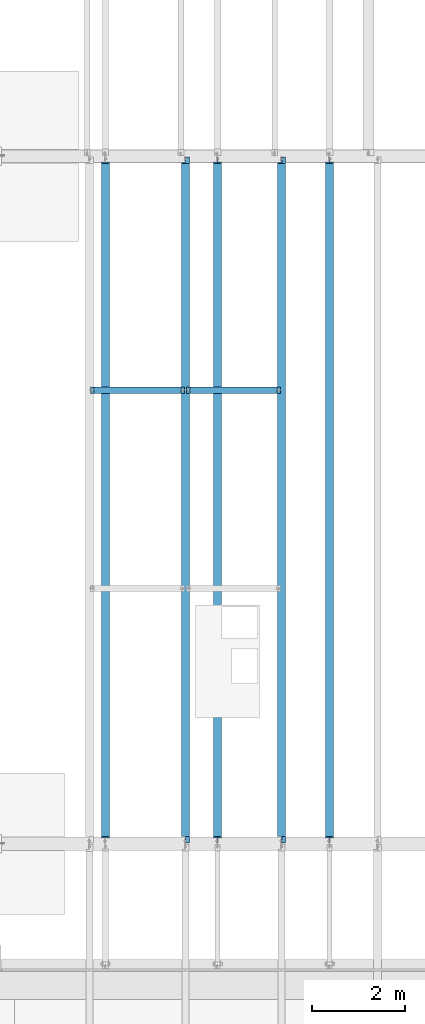
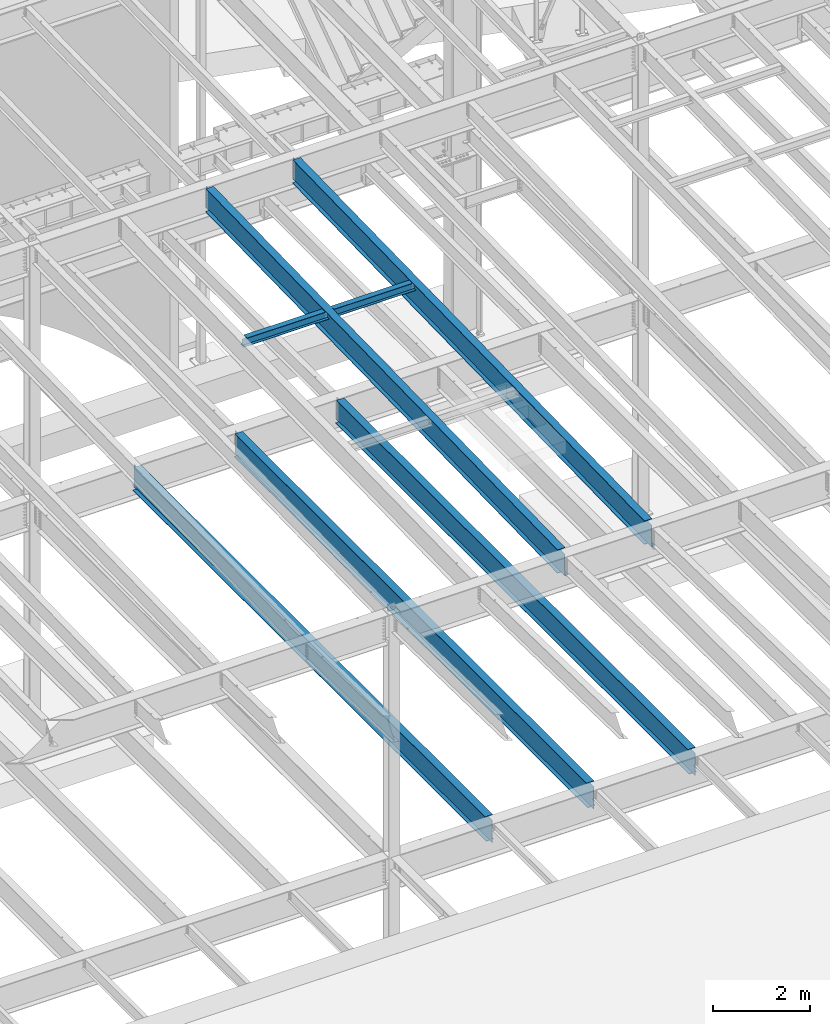
# One storey, part 1107 of 1763: 7 beams, 7 elements without a shape of their own.
"""IFC2X3 building model written with IfcOpenShell, lengths in millimetres."""

from ifc_helpers import new_model, si_unit, frame, origin_with_axes, place, context, subcontext, project, spatial, faceted_brep, material, type_object, element, aggregate, save


model = new_model("IFC2X3")

# Units and contexts
model_context = context("Model", 3, precision=1e-05, world=origin_with_axes())
body_context = subcontext(model_context, "Body", "Model", "MODEL_VIEW")
ifc_project = project(units=[si_unit("LENGTHUNIT", "METRE", prefix="MILLI"), si_unit("AREAUNIT", "SQUARE_METRE"), si_unit("VOLUMEUNIT", "CUBIC_METRE"), si_unit("MASSUNIT", "GRAM", prefix="KILO"), si_unit("TIMEUNIT", "SECOND"), si_unit("PLANEANGLEUNIT", "RADIAN"), si_unit("SOLIDANGLEUNIT", "STERADIAN"), si_unit("THERMODYNAMICTEMPERATUREUNIT", "DEGREE_CELSIUS"), si_unit("LUMINOUSINTENSITYUNIT", "LUMEN")], contexts=[model_context])

# Site, building, storey
site_placement = place(None, origin_with_axes())
site = spatial("IfcSite", under=ifc_project, at=site_placement, CompositionType="ELEMENT")
building_placement = place(site_placement, origin_with_axes())
building = spatial("IfcBuilding", under=site, at=building_placement, Name="Undefined", CompositionType="ELEMENT")
storey_placement = place(building_placement, origin_with_axes())
storey = spatial("IfcBuildingStorey", under=building, at=storey_placement, Name="Undefined", CompositionType="ELEMENT", Elevation=0.0)

# Assembly, beam
assembly_1_placement = place(storey_placement, origin_with_axes())
assembly_1 = element("IfcElementAssembly", 1, at=assembly_1_placement, inside=storey, Name="BEAM", AssemblyPlace="NOTDEFINED", PredefinedType="RIGID_FRAME")
ifc_material = material(Name="STEEL/A992")
beam_type_1 = type_object("IfcBeamType", Name="W8X18", PredefinedType="NOTDEFINED")
beam_1_placement = place(assembly_1_placement, frame((-45273.1229879841, 39776.399940754, 11388.9111170495), z_axis=(0.0, 0.0, 1.0), x_axis=(1.0, 0.0, 0.0)))
beam_1 = element("IfcBeam", 2, at=beam_1_placement, type_object=beam_type_1, material=ifc_material, Name="BEAM", ObjectType="W8X18", context=body_context, shape_type="Brep", body=[
    faceted_brep([(87.3125001907247, -3.17500000000018, 64.8275016680727), (87.3125001907247, 3.17500000000018, 64.8275016680727), (17.4624999999905, 3.17500000000018, 64.8275016680727), (17.4624999999905, -3.17500000000018, 64.8275016680727), (92.1725797087711, -3.17500000000018, 65.7942315906603), (92.1725797087711, 3.17500000000018, 65.7942315906603), (96.2927561769247, -3.17500000000018, 68.5472454911378), (96.2927561769247, 3.17500000000018, 68.5472454911378), (97.153740969894, -3.17499999999927, 69.8358003008998), (97.153740969894, 3.17499999999927, 69.8358003008998), (17.4624999999905, -3.17500000000018, -95.25), (17.4624999999905, -66.6750000000002, -95.25), (2047.19464159034, -66.675000005067, -95.25), (2047.19464279684, -3.17500000506698, -95.25), (17.4624999999905, -66.6750000000002, -103.1875), (2047.19464159034, -66.675000005067, -103.1875), (17.4624999999905, 66.6750000000002, -103.1875), (2047.19464412399, 66.6749999949316, -103.1875), (17.4624999999905, 66.6750000000002, -95.25), (2047.19464412399, 66.6749999949316, -95.25), (17.4624999999905, 3.17500000000018, -95.25), (2047.19464291749, 3.17499999493157, -95.25), (2047.19464291749, 3.17499999493157, 64.8275016776788), (2047.19464279684, -3.17500000506698, 64.8275016776788), (1977.34464266644, 3.17499999509891, 64.8275016776788), (1977.34464266642, -3.17500000489963, 64.8275016776788), (1972.48456314837, 3.17499999999927, 65.794231601054), (1972.48456314837, -3.17499999999927, 65.794231601054), (1968.36438668022, 3.17499999999927, 68.5472455015315), (1968.36438668022, -3.17499999999927, 68.5472455015315), (1967.50340238101, 3.17499999512802, 69.8357995645329), (1967.50340247829, -3.17500000487053, 69.8357994189137), (1966.77688980176, 3.17499999512802, 70.3212397501684), (1966.77688968111, -3.17500000487053, 70.3212397501684), (1964.02387590129, 3.17499999513529, 74.441416218322), (1964.02387578064, -3.17500000486325, 74.441416218322), (1963.0571459787, 3.17499999514257, 79.3014957363666), (1963.05714585805, -3.17500000485597, 79.3014957363666), (1963.05714465155, -66.675000004856, 103.1875), (1963.05714465155, -66.675000004856, 95.25), (1963.05714585805, -3.17500000485597, 95.25), (1963.0571459787, 3.17499999514257, 95.25), (1963.05714718519, 66.6749999951426, 95.25), (1963.05714718519, 66.6749999951426, 103.1875), (101.599996948244, 3.17500000000018, 95.25), (101.599996948244, 66.6750000000002, 95.25), (101.599996948244, 66.6750000000002, 103.1875), (101.599996948244, -66.6750000000002, 103.1875), (101.599996948244, -66.6750000000002, 95.25), (101.599996948244, -3.17500000000018, 95.25), (101.599996948236, 3.17499999999927, 79.301496189446), (101.599996948236, -3.17499999999927, 79.301496189446), (100.633267025652, 3.17499999999927, 74.4414166713996), (100.633267025652, -3.17499999999927, 74.4414166713996), (97.8802531251713, 3.17499999999927, 70.3212402032459), (97.8802531251713, -3.17499999999927, 70.3212402032459)], [[[0, 1, 2, 3]], [[4, 5, 1, 0]], [[6, 7, 5, 4]], [[8, 9, 7, 6]], [[10, 11, 12, 13]], [[11, 14, 15, 12]], [[14, 16, 17, 15]], [[16, 18, 19, 17]], [[18, 20, 21, 19]], [[13, 12, 15, 17, 19, 21, 22, 23]], [[23, 22, 24, 25]], [[25, 24, 26, 27]], [[27, 26, 28, 29]], [[29, 28, 30, 31]], [[32, 33, 31, 30]], [[33, 32, 34, 35]], [[35, 34, 36, 37]], [[38, 39, 40, 37, 36, 41, 42, 43]], [[42, 41, 44, 45]], [[43, 42, 45, 46]], [[38, 43, 46, 47]], [[39, 38, 47, 48]], [[40, 39, 48, 49]], [[47, 46, 45, 44, 50, 51, 49, 48]], [[51, 50, 52, 53]], [[53, 52, 54, 55]], [[27, 29, 31, 33, 35, 37, 40, 49, 51, 53, 55, 8, 6, 4, 0, 3, 10, 13, 23, 25]], [[20, 18, 16, 14, 11, 10, 3, 2]], [[21, 20, 2, 1, 5, 7, 9, 54, 52, 50, 44, 41, 36, 34, 32, 30, 28, 26, 24, 22]], [[55, 54, 9, 8]]]),
])
aggregate(assembly_1, [beam_1])

assembly_2_placement = place(storey_placement, origin_with_axes())
assembly_2 = element("IfcElementAssembly", 3, at=assembly_2_placement, inside=storey, Name="BEAM", AssemblyPlace="NOTDEFINED", PredefinedType="RIGID_FRAME")
beam_2_placement = place(assembly_2_placement, frame((-47337.7801308412, 39776.4, 11388.9111170495), z_axis=(0.0, 0.0, 1.0), x_axis=(1.0, 0.0, 0.0)))
beam_2 = element("IfcBeam", 4, at=beam_2_placement, type_object=beam_type_1, material=ifc_material, Name="BEAM", ObjectType="W8X18", context=body_context, shape_type="Brep", body=[
    faceted_brep([(1968.36438668022, -3.17499999999927, 68.5472455015315), (1968.36438668022, 3.17499999999927, 68.5472455015315), (1967.50340238101, 3.17499999512802, 69.8357995645329), (1967.50340247829, -3.17500000487053, 69.8357994189137), (1972.48456314837, -3.17499999999927, 65.794231601054), (1972.48456314837, 3.17499999999927, 65.794231601054), (1977.34464266642, -3.17500000489963, 64.8275016776788), (1977.34464266644, 3.17499999509891, 64.8275016776788), (2047.19464279684, -3.17500000506698, 64.8275016776788), (2047.19464291749, 3.17499999493157, 64.8275016776788), (1966.77688968111, -3.17500000487053, 70.3212397501684), (1966.77688980176, 3.17499999512802, 70.3212397501684), (1964.02387590129, 3.17499999513529, 74.441416218322), (1964.02387578064, -3.17500000486325, 74.441416218322), (1963.0571459787, 3.17499999514257, 79.3014957363666), (1963.05714585805, -3.17500000485597, 79.3014957363666), (1963.05714718519, 66.6749999951426, 95.25), (1963.0571459787, 3.17499999514257, 95.25), (101.599996948244, 3.17500000000018, 95.25), (101.599996948244, 66.6750000000002, 95.25), (1963.05714465155, -66.675000004856, 95.25), (1963.05714465155, -66.675000004856, 103.1875), (101.599996948244, -66.6750000000002, 103.1875), (101.599996948244, -66.6750000000002, 95.25), (1963.05714718519, 66.6749999951426, 103.1875), (101.599996948244, 66.6750000000002, 103.1875), (1963.05714585805, -3.17500000485597, 95.25), (101.599996948244, -3.17500000000018, 95.25), (101.599996948236, 3.17499999999927, 79.301496189446), (101.599996948236, -3.17499999999927, 79.301496189446), (100.633267025652, 3.17499999999927, 74.4414166713996), (100.633267025652, -3.17499999999927, 74.4414166713996), (97.8802531251713, 3.17499999999927, 70.3212402032459), (97.8802531251713, -3.17499999999927, 70.3212402032459), (97.153740969894, 3.17499999999927, 69.8358003008998), (97.153740969894, -3.17499999999927, 69.8358003008998), (96.2927561769247, 3.17500000000018, 68.5472454911378), (96.2927561769247, -3.17500000000018, 68.5472454911378), (92.1725797087711, 3.17500000000018, 65.7942315906603), (92.1725797087711, -3.17500000000018, 65.7942315906603), (87.3125001907247, 3.17500000000018, 64.8275016680727), (87.3125001907247, -3.17500000000018, 64.8275016680727), (17.4624999999905, 3.17500000000018, 64.8275016680727), (17.4624999999905, -3.17500000000018, 64.8275016680727), (17.4624999999905, 3.17500000000018, -95.25), (17.4624999999905, 66.6750000000002, -95.25), (17.4624999999905, 66.6750000000002, -103.1875), (17.4624999999905, -66.6750000000002, -103.1875), (17.4624999999905, -66.6750000000002, -95.25), (17.4624999999905, -3.17500000000018, -95.25), (2047.19464291749, 3.17499999493157, -95.25), (2047.19464412399, 66.6749999949316, -95.25), (2047.19464412399, 66.6749999949316, -103.1875), (2047.19464159034, -66.675000005067, -103.1875), (2047.19464159034, -66.675000005067, -95.25), (2047.19464279684, -3.17500000506698, -95.25)], [[[0, 1, 2, 3]], [[4, 5, 1, 0]], [[6, 7, 5, 4]], [[8, 9, 7, 6]], [[10, 11, 12, 13]], [[13, 12, 14, 15]], [[16, 17, 18, 19]], [[20, 21, 22, 23]], [[21, 24, 25, 22]], [[24, 16, 19, 25]], [[21, 20, 26, 15, 14, 17, 16, 24]], [[26, 20, 23, 27]], [[22, 25, 19, 18, 28, 29, 27, 23]], [[29, 28, 30, 31]], [[31, 30, 32, 33]], [[33, 32, 34, 35]], [[35, 34, 36, 37]], [[37, 36, 38, 39]], [[39, 38, 40, 41]], [[41, 40, 42, 43]], [[44, 45, 46, 47, 48, 49, 43, 42]], [[45, 44, 50, 51]], [[46, 45, 51, 52]], [[47, 46, 52, 53]], [[48, 47, 53, 54]], [[49, 48, 54, 55]], [[4, 0, 3, 10, 13, 15, 26, 27, 29, 31, 33, 35, 37, 39, 41, 43, 49, 55, 8, 6]], [[11, 10, 3, 2]], [[50, 44, 42, 40, 38, 36, 34, 32, 30, 28, 18, 17, 14, 12, 11, 2, 1, 5, 7, 9]], [[55, 54, 53, 52, 51, 50, 9, 8]]]),
])
aggregate(assembly_2, [beam_2])

assembly_3_placement = place(storey_placement, origin_with_axes())
assembly_3 = element("IfcElementAssembly", 5, at=assembly_3_placement, inside=storey, Name="BEAM", AssemblyPlace="NOTDEFINED", PredefinedType="RIGID_FRAME")
beam_type_2 = type_object("IfcBeamType", Name="W24X55", PredefinedType="NOTDEFINED")
beam_3_placement = place(assembly_3_placement, frame((-43208.4658451269, 30029.006344251, 10990.3266966851), z_axis=(0.0, -0.0206852279954837, 0.999786037781472), x_axis=(0.0, 0.999786037781472, 0.0206852279954825)))
beam_3 = element("IfcBeam", 6, at=beam_3_placement, type_object=beam_type_2, material=ifc_material, Name="BEAM", ObjectType="W24X55", context=body_context, shape_type="Brep", body=[
    faceted_brep([(159.690329536948, 5.06237880352273, -287.337499999812), (159.690329536945, 5.06261812614684, -300.037499999804), (7.43265181667448, 5.06260883843788, -300.037499999775), (7.69541043263234, 5.06236953187909, -287.337499999783), (159.690324423107, 88.9000000000015, -287.337499999812), (159.690324423103, 88.9000000000015, -300.037499999802), (159.690324117899, -4.76249999999709, 261.677501487318), (159.690324117899, 4.76249999999709, 261.677501487318), (158.723594195311, 4.76249999999709, 256.817421969285), (158.723594195311, -4.76249999999709, 256.817421969285), (155.970580294834, 4.76249999999709, 252.697245501142), (155.970580294834, -4.76249999999709, 252.697245501142), (151.850403826695, 4.76249999999709, 249.944231600668), (151.850403826695, -4.76249999999709, 249.944231600668), (146.990324308659, 4.76249999999709, 248.977501678084), (146.990324308659, -4.76249999999709, 248.977501678084), (18.7915826813696, 4.76249999999709, 248.97750167811), (18.7915826813696, -4.76249999999709, 248.97750167811), (7.69541043263234, -4.76249999999709, -287.337499999783), (14754.7569745369, -4.76249999999709, -287.337500002592), (14765.8531467848, -4.76249999999709, 248.977501635871), (14640.0518880073, -4.76249999999709, 248.977501635894), (14635.1918084892, -4.76249999999709, 249.944231558482), (14631.0716320211, -4.76249999999709, 252.697245458956), (14628.3186181206, -4.76249999999709, 256.817421927099), (14627.351888198, -4.76249999999709, 261.677501445134), (14627.351888198, -4.76249999999709, 287.337499997), (159.690324117902, -4.76249999999709, 287.337499999756), (7.69541043263234, -88.9000000000015, -287.337499999783), (14754.7569745369, -88.9000000000015, -287.337500002592), (7.43265181667448, -88.9000000000015, -300.037499999775), (14754.4942159209, -88.9000000000015, -300.037500002583), (14640.051883239, 5.06261810508295, -287.33750000257), (14640.051883239, 5.06237878320098, -300.03750000256), (14640.0518719211, 88.9000000000015, -300.037500002562), (14640.0518719211, 88.9000000000015, -287.337500002572), (14754.7569745369, 5.0626335900306, -287.337500002592), (14754.4942159209, 5.06239423266379, -300.037500002583), (14754.7569745369, 4.76249999999709, -287.337500002592), (14765.8531467848, 4.76249999999709, 248.977501635871), (14640.0518880073, 4.76249999999709, 248.977501635894), (14635.1918084892, 4.76249999999709, 249.944231558482), (14631.0716320211, 4.76249999999709, 252.697245458956), (14628.3186181206, 4.76249999999709, 256.817421927099), (14627.351888198, 4.76249999999709, 261.677501445134), (14627.351888198, -88.9000000000015, 300.03749999699), (14627.351888198, -88.9000000000015, 287.337499997), (14627.351888198, 4.76249999999709, 287.337499997), (14627.351888198, 88.9000000000015, 287.337499997), (14627.351888198, 88.9000000000015, 300.03749999699), (159.690324117902, 4.76249999999709, 287.337499999756), (159.690324117902, 88.9000000000015, 287.337499999756), (159.690324117906, 88.9000000000015, 300.037499999746), (159.690324117906, -88.9000000000015, 300.037499999746), (159.690324117902, -88.9000000000015, 287.337499999756), (7.69541043263234, 4.76249999999709, -287.337499999783)], [[[0, 1, 2, 3]], [[4, 5, 1, 0]], [[6, 7, 8, 9]], [[9, 8, 10, 11]], [[11, 10, 12, 13]], [[13, 12, 14, 15]], [[15, 14, 16, 17]], [[9, 11, 13, 15, 17, 18, 19, 20, 21, 22, 23, 24, 25, 26, 27, 6]], [[18, 28, 29, 19]], [[28, 30, 31, 29]], [[32, 33, 34, 35]], [[36, 37, 33, 32]], [[38, 39, 20, 19, 29, 31, 37, 36]], [[20, 39, 40, 21]], [[21, 40, 41, 22]], [[22, 41, 42, 23]], [[23, 42, 43, 24]], [[24, 43, 44, 25]], [[45, 46, 26, 25, 44, 47, 48, 49]], [[48, 47, 50, 51]], [[49, 48, 51, 52]], [[45, 49, 52, 53]], [[46, 45, 53, 54]], [[26, 46, 54, 27]], [[53, 52, 51, 50, 7, 6, 27, 54]], [[47, 44, 43, 42, 41, 40, 39, 38, 55, 16, 14, 12, 10, 8, 7, 50]], [[30, 28, 18, 17, 16, 55, 3, 2]], [[34, 33, 37, 31, 30, 2, 1, 5]], [[35, 34, 5, 4]], [[55, 38, 36, 32, 35, 4, 0, 3]]]),
])
aggregate(assembly_3, [beam_3])

assembly_4_placement = place(storey_placement, origin_with_axes())
assembly_4 = element("IfcElementAssembly", 7, at=assembly_4_placement, inside=storey, Name="BEAM", AssemblyPlace="NOTDEFINED", PredefinedType="RIGID_FRAME")
beam_4_placement = place(assembly_4_placement, frame((-45273.1229879841, 30029.0062849784, 10990.3266966851), z_axis=(0.0, -0.0206852279954837, 0.999786037781472), x_axis=(0.0, 0.999786037781472, 0.0206852279954825)))
beam_4 = element("IfcBeam", 8, at=beam_4_placement, type_object=beam_type_2, material=ifc_material, Name="BEAM", ObjectType="W24X55", context=body_context, shape_type="Brep", body=[
    faceted_brep([(159.690388822928, 5.06237880515255, -287.337499999814), (159.690388822924, 5.06261812777666, -300.037499999802), (7.43271110196656, 5.0626088400677, -300.037499999775), (7.69546971792806, 5.0623695335089, -287.337499999783), (159.690383709101, 88.9000000000015, -287.337499999812), (159.690383709098, 88.9000000000015, -300.037499999802), (159.690383403184, -4.76249999999709, 261.677501487313), (159.690383403184, 4.76249999999709, 261.677501487313), (158.7236534806, 4.76249999999709, 256.817421969279), (158.7236534806, -4.76249999999709, 256.817421969279), (155.970639580122, 4.76249999999709, 252.697245501135), (155.970639580122, -4.76249999999709, 252.697245501135), (151.850463111983, 4.76249999999709, 249.944231600663), (151.850463111983, -4.76249999999709, 249.944231600663), (146.990383593948, 4.76249999999709, 248.977501678079), (146.990383593948, -4.76249999999709, 248.977501678079), (18.7916419666617, 4.76249999999709, 248.977501678104), (18.7916419666617, -4.76249999999709, 248.977501678104), (7.69546971792806, -4.76249999999709, -287.337499999783), (14754.7570338222, -4.76249999999709, -287.337500002592), (14765.8532060701, -4.76249999999709, 248.977501635885), (14640.0519472926, -4.76249999999709, 248.977501635911), (14635.1918677746, -4.76249999999709, 249.944231558498), (14631.0716913064, -4.76249999999709, 252.69724545897), (14628.3186774059, -4.76249999999709, 256.817421927115), (14627.3519474833, -4.76249999999709, 261.677501445149), (14627.3519474833, -4.76249999999709, 287.337499997), (159.690383403191, -4.76249999999709, 287.337499999756), (7.69546971792806, -88.9000000000015, -287.337499999783), (14754.7570338222, -88.9000000000015, -287.337500002592), (7.43271110196656, -88.9000000000015, -300.037499999775), (14754.4942752062, -88.9000000000015, -300.037500002583), (14640.0519425246, 5.06261810519209, -287.33750000257), (14640.0519425247, 5.06237878331012, -300.037500002562), (14640.0519312068, 88.9000000000015, -300.03750000256), (14640.0519312068, 88.9000000000015, -287.337500002572), (14754.7570338222, 5.06263359013974, -287.337500002592), (14754.4942752062, 5.06239423277293, -300.037500002583), (14754.7570338222, 4.76249999999709, -287.337500002592), (14765.8532060701, 4.76249999999709, 248.977501635885), (14640.0519472926, 4.76249999999709, 248.977501635911), (14635.1918677746, 4.76249999999709, 249.944231558498), (14631.0716913064, 4.76249999999709, 252.69724545897), (14628.3186774059, 4.76249999999709, 256.817421927115), (14627.3519474833, 4.76249999999709, 261.677501445149), (14627.3519474833, -88.9000000000015, 300.03749999699), (14627.3519474833, -88.9000000000015, 287.337499997), (14627.3519474833, 4.76249999999709, 287.337499997), (14627.3519474833, 88.9000000000015, 287.337499997), (14627.3519474833, 88.9000000000015, 300.03749999699), (159.690383403191, 4.76249999999709, 287.337499999756), (159.690383403191, 88.9000000000015, 287.337499999756), (159.690383403195, 88.9000000000015, 300.037499999746), (159.690383403195, -88.9000000000015, 300.037499999746), (159.690383403191, -88.9000000000015, 287.337499999756), (7.69546971792806, 4.76249999999709, -287.337499999783)], [[[0, 1, 2, 3]], [[4, 5, 1, 0]], [[6, 7, 8, 9]], [[9, 8, 10, 11]], [[11, 10, 12, 13]], [[13, 12, 14, 15]], [[15, 14, 16, 17]], [[9, 11, 13, 15, 17, 18, 19, 20, 21, 22, 23, 24, 25, 26, 27, 6]], [[18, 28, 29, 19]], [[28, 30, 31, 29]], [[32, 33, 34, 35]], [[36, 37, 33, 32]], [[38, 39, 20, 19, 29, 31, 37, 36]], [[20, 39, 40, 21]], [[21, 40, 41, 22]], [[22, 41, 42, 23]], [[23, 42, 43, 24]], [[24, 43, 44, 25]], [[45, 46, 26, 25, 44, 47, 48, 49]], [[48, 47, 50, 51]], [[49, 48, 51, 52]], [[45, 49, 52, 53]], [[46, 45, 53, 54]], [[26, 46, 54, 27]], [[53, 52, 51, 50, 7, 6, 27, 54]], [[47, 44, 43, 42, 41, 40, 39, 38, 55, 16, 14, 12, 10, 8, 7, 50]], [[30, 28, 18, 17, 16, 55, 3, 2]], [[34, 33, 37, 31, 30, 2, 1, 5]], [[35, 34, 5, 4]], [[55, 38, 36, 32, 35, 4, 0, 3]]]),
])
aggregate(assembly_4, [beam_4])

assembly_5_placement = place(storey_placement, origin_with_axes())
assembly_5 = element("IfcElementAssembly", 9, at=assembly_5_placement, inside=storey, Name="BEAM", AssemblyPlace="NOTDEFINED", PredefinedType="RIGID_FRAME")
beam_5_placement = place(assembly_5_placement, frame((-42176.1372736983, 30022.8, 4894.2625), z_axis=(0.0, 0.0, 1.0), x_axis=(0.0, 1.0, 0.0)))
beam_5 = element("IfcBeam", 10, at=beam_5_placement, type_object=beam_type_2, material=ifc_material, Name="BEAM", ObjectType="W24X55", context=body_context, shape_type="Brep", body=[
    faceted_brep([(19.8437500000036, -5.06263076800678, -287.3375), (19.8437500000036, -5.06239138569799, -300.0375), (121.443760724065, -5.06237878766842, -300.0375), (121.443760724113, -5.06261816997721, -287.3375), (121.443815955325, -88.9000000000015, -287.3375), (121.443815955325, -88.9000000000015, -300.0375), (159.543750000004, -4.76249999999709, 280.727501487732), (159.543750000004, 4.76249999999709, 280.727501487732), (158.577020077417, 4.76249999999709, 275.867421969687), (158.577020077417, -4.76249999999709, 275.867421969687), (155.824006176939, 4.76249999999709, 271.747245501533), (155.824006176939, -4.76249999999709, 271.747245501533), (151.703829708786, 4.76249999999709, 268.994231601055), (151.703829708786, -4.76249999999709, 268.994231601055), (146.843750190739, 4.76249999999709, 268.027501678467), (146.843750190739, -4.76249999999709, 268.027501678467), (19.8437500000036, 4.76249999999709, 268.027501678467), (19.8437500000036, -4.76249999999709, 268.027501678467), (19.84375, -4.76249999999709, -287.3375), (14762.95625, -4.76249999999709, -287.3375), (14762.95625, -4.76249999999709, 268.027501678467), (14635.9562498093, -4.76249999999709, 268.027501678467), (14631.0961702912, -4.76249999999709, 268.994231601055), (14626.9759938231, -4.76249999999709, 271.747245501533), (14624.2229799226, -4.76249999999709, 275.867421969687), (14623.25625, -4.76249999999709, 280.727501487732), (14623.25625, -4.76249999999709, 287.3375), (159.543750000004, -4.76249999999709, 287.3375), (14762.95625, 4.76249999999709, 268.027501678467), (14635.9562498093, 4.76249999999709, 268.027501678467), (14631.0961702912, 4.76249999999709, 268.994231601055), (14626.9759938231, 4.76249999999709, 271.747245501533), (14624.2229799226, 4.76249999999709, 275.867421969687), (14623.25625, 4.76249999999709, 280.727501487732), (14623.25625, -88.8999999999942, 300.0375), (14623.25625, -88.8999999999942, 287.3375), (14623.25625, 4.76249999999709, 287.3375), (14623.25625, 88.8999999999942, 287.3375), (14623.25625, 88.8999999999942, 300.0375), (159.543750000004, 4.76249999999709, 287.3375), (159.543750000004, 88.8999999999942, 287.3375), (159.543750000004, 88.8999999999942, 300.0375), (159.543750000004, -88.8999999999942, 300.0375), (159.543750000004, -88.8999999999942, 287.3375), (14762.95625, 4.76249999999709, -287.3375), (19.84375, 4.76249999999709, -287.3375), (14762.95625, 5.0626307680941, -287.3375), (14661.3562392746, 5.06261817002087, -287.3375), (14661.356228879, 88.8999999999942, -287.3375), (121.443751839222, 88.9000000000015, -287.3375), (121.443761016704, 5.06237876559317, -287.3375), (19.8437500000036, 5.06236616715614, -287.3375), (121.443761016661, 5.06261814791651, -300.0375), (19.8437500000036, 5.06260554946493, -300.0375), (121.443751839222, 88.9000000000015, -300.0375), (14661.356228879, 88.8999999999942, -300.0375), (14661.3562392746, 5.06237878771208, -300.0375), (14762.95625, 5.0623913857853, -300.0375), (14762.95625, -5.06236616667593, -287.3375), (14762.95625, -5.06260554897017, -300.0375), (14661.3562389844, -5.0623787647346, -287.3375), (14661.3562389844, -5.06261814705795, -300.0375), (14661.3562493798, -88.8999999999942, -287.3375), (14661.3562493798, -88.8999999999942, -300.0375)], [[[0, 1, 2, 3]], [[4, 3, 2, 5]], [[6, 7, 8, 9]], [[9, 8, 10, 11]], [[11, 10, 12, 13]], [[13, 12, 14, 15]], [[15, 14, 16, 17]], [[9, 11, 13, 15, 17, 18, 19, 20, 21, 22, 23, 24, 25, 26, 27, 6]], [[20, 28, 29, 21]], [[21, 29, 30, 22]], [[22, 30, 31, 23]], [[23, 31, 32, 24]], [[24, 32, 33, 25]], [[34, 35, 26, 25, 33, 36, 37, 38]], [[37, 36, 39, 40]], [[38, 37, 40, 41]], [[34, 38, 41, 42]], [[35, 34, 42, 43]], [[26, 35, 43, 27]], [[42, 41, 40, 39, 7, 6, 27, 43]], [[36, 33, 32, 31, 30, 29, 28, 44, 45, 16, 14, 12, 10, 8, 7, 39]], [[45, 44, 46, 47, 48, 49, 50, 51]], [[50, 52, 53, 51]], [[49, 54, 52, 50]], [[48, 55, 54, 49]], [[47, 56, 55, 48]], [[46, 57, 56, 47]], [[44, 28, 20, 19, 58, 59, 57, 46]], [[58, 60, 61, 59]], [[62, 63, 61, 60]], [[63, 62, 4, 5]], [[1, 53, 52, 54, 55, 56, 57, 59, 61, 63, 5, 2]], [[18, 17, 16, 45, 51, 53, 1, 0]], [[62, 60, 58, 19, 18, 0, 3, 4]]]),
])
aggregate(assembly_5, [beam_5])

assembly_6_placement = place(storey_placement, origin_with_axes())
assembly_6 = element("IfcElementAssembly", 11, at=assembly_6_placement, inside=storey, Name="BEAM", AssemblyPlace="NOTDEFINED", PredefinedType="RIGID_FRAME")
beam_6_placement = place(assembly_6_placement, frame((-44584.903940365, 30022.8, 4894.2625), z_axis=(0.0, 0.0, 1.0), x_axis=(0.0, 1.0, 0.0)))
beam_6 = element("IfcBeam", 12, at=beam_6_placement, type_object=beam_type_2, material=ifc_material, Name="BEAM", ObjectType="W24X55", context=body_context, shape_type="Brep", body=[
    faceted_brep([(19.8437500000036, -5.06263076800678, -287.3375), (19.8437500000036, -5.06239138569799, -300.0375), (121.443760724065, -5.06237878766842, -300.0375), (121.443760724113, -5.06261816997721, -287.3375), (121.443815955325, -88.9000000000015, -287.3375), (121.443815955325, -88.9000000000015, -300.0375), (159.543750000004, -4.76249999999709, 280.727501487732), (159.543750000004, 4.76249999999709, 280.727501487732), (158.577020077417, 4.76249999999709, 275.867421969687), (158.577020077417, -4.76249999999709, 275.867421969687), (155.824006176939, 4.76249999999709, 271.747245501533), (155.824006176939, -4.76249999999709, 271.747245501533), (151.703829708786, 4.76249999999709, 268.994231601055), (151.703829708786, -4.76249999999709, 268.994231601055), (146.843750190739, 4.76249999999709, 268.027501678467), (146.843750190739, -4.76249999999709, 268.027501678467), (19.8437500000036, 4.76249999999709, 268.027501678467), (19.8437500000036, -4.76249999999709, 268.027501678467), (19.84375, -4.76249999999709, -287.3375), (14762.95625, -4.76249999999709, -287.3375), (14762.95625, -4.76249999999709, 268.027501678467), (14635.9562498093, -4.76249999999709, 268.027501678467), (14631.0961702912, -4.76249999999709, 268.994231601055), (14626.9759938231, -4.76249999999709, 271.747245501533), (14624.2229799226, -4.76249999999709, 275.867421969687), (14623.25625, -4.76249999999709, 280.727501487732), (14623.25625, -4.76249999999709, 287.3375), (159.543750000004, -4.76249999999709, 287.3375), (14762.95625, 4.76249999999709, 268.027501678467), (14635.9562498093, 4.76249999999709, 268.027501678467), (14631.0961702912, 4.76249999999709, 268.994231601055), (14626.9759938231, 4.76249999999709, 271.747245501533), (14624.2229799226, 4.76249999999709, 275.867421969687), (14623.25625, 4.76249999999709, 280.727501487732), (14623.25625, -88.8999999999942, 300.0375), (14623.25625, -88.8999999999942, 287.3375), (14623.25625, 4.76249999999709, 287.3375), (14623.25625, 88.8999999999942, 287.3375), (14623.25625, 88.8999999999942, 300.0375), (159.543750000004, 4.76249999999709, 287.3375), (159.543750000004, 88.8999999999942, 287.3375), (159.543750000004, 88.8999999999942, 300.0375), (159.543750000004, -88.8999999999942, 300.0375), (159.543750000004, -88.8999999999942, 287.3375), (14762.95625, 4.76249999999709, -287.3375), (19.84375, 4.76249999999709, -287.3375), (14762.95625, 5.0626307680941, -287.3375), (14661.3562392746, 5.06261817002087, -287.3375), (14661.356228879, 88.8999999999942, -287.3375), (121.443751839222, 88.9000000000015, -287.3375), (121.443761016704, 5.06237876559317, -287.3375), (19.8437500000036, 5.06236616715614, -287.3375), (121.443761016661, 5.06261814791651, -300.0375), (19.8437500000036, 5.06260554946493, -300.0375), (121.443751839222, 88.9000000000015, -300.0375), (14661.356228879, 88.8999999999942, -300.0375), (14661.3562392746, 5.06237878771208, -300.0375), (14762.95625, 5.0623913857853, -300.0375), (14762.95625, -5.06236616667593, -287.3375), (14762.95625, -5.06260554897017, -300.0375), (14661.3562389844, -5.0623787647346, -287.3375), (14661.3562389844, -5.06261814705795, -300.0375), (14661.3562493798, -88.8999999999942, -287.3375), (14661.3562493798, -88.8999999999942, -300.0375)], [[[0, 1, 2, 3]], [[4, 3, 2, 5]], [[6, 7, 8, 9]], [[9, 8, 10, 11]], [[11, 10, 12, 13]], [[13, 12, 14, 15]], [[15, 14, 16, 17]], [[9, 11, 13, 15, 17, 18, 19, 20, 21, 22, 23, 24, 25, 26, 27, 6]], [[20, 28, 29, 21]], [[21, 29, 30, 22]], [[22, 30, 31, 23]], [[23, 31, 32, 24]], [[24, 32, 33, 25]], [[34, 35, 26, 25, 33, 36, 37, 38]], [[37, 36, 39, 40]], [[38, 37, 40, 41]], [[34, 38, 41, 42]], [[35, 34, 42, 43]], [[26, 35, 43, 27]], [[42, 41, 40, 39, 7, 6, 27, 43]], [[36, 33, 32, 31, 30, 29, 28, 44, 45, 16, 14, 12, 10, 8, 7, 39]], [[45, 44, 46, 47, 48, 49, 50, 51]], [[50, 52, 53, 51]], [[49, 54, 52, 50]], [[48, 55, 54, 49]], [[47, 56, 55, 48]], [[46, 57, 56, 47]], [[44, 28, 20, 19, 58, 59, 57, 46]], [[58, 60, 61, 59]], [[62, 63, 61, 60]], [[63, 62, 4, 5]], [[1, 53, 52, 54, 55, 56, 57, 59, 61, 63, 5, 2]], [[18, 17, 16, 45, 51, 53, 1, 0]], [[62, 60, 58, 19, 18, 0, 3, 4]]]),
])
aggregate(assembly_6, [beam_6])

assembly_7_placement = place(storey_placement, origin_with_axes())
assembly_7 = element("IfcElementAssembly", 13, at=assembly_7_placement, inside=storey, Name="BEAM", AssemblyPlace="NOTDEFINED", PredefinedType="RIGID_FRAME")
beam_7_placement = place(assembly_7_placement, frame((-46993.6706070317, 30022.8, 4894.2625), z_axis=(0.0, 0.0, 1.0), x_axis=(0.0, 1.0, 0.0)))
beam_7 = element("IfcBeam", 14, at=beam_7_placement, type_object=beam_type_2, material=ifc_material, Name="BEAM", ObjectType="W24X55", context=body_context, shape_type="Brep", body=[
    faceted_brep([(19.8437500000036, -5.06263076800678, -287.3375), (19.8437500000036, -5.06239138569799, -300.0375), (121.443760724065, -5.06237878766842, -300.0375), (121.443760724113, -5.06261816997721, -287.3375), (121.443815955325, -88.9000000000015, -287.3375), (121.443815955325, -88.9000000000015, -300.0375), (159.543750000004, -4.76249999999709, 280.727501487732), (159.543750000004, 4.76249999999709, 280.727501487732), (158.577020077417, 4.76249999999709, 275.867421969687), (158.577020077417, -4.76249999999709, 275.867421969687), (155.824006176939, 4.76249999999709, 271.747245501533), (155.824006176939, -4.76249999999709, 271.747245501533), (151.703829708786, 4.76249999999709, 268.994231601055), (151.703829708786, -4.76249999999709, 268.994231601055), (146.843750190739, 4.76249999999709, 268.027501678467), (146.843750190739, -4.76249999999709, 268.027501678467), (19.8437500000036, 4.76249999999709, 268.027501678467), (19.8437500000036, -4.76249999999709, 268.027501678467), (19.84375, -4.76249999999709, -287.3375), (14762.95625, -4.76249999999709, -287.3375), (14762.95625, -4.76249999999709, 268.027501678467), (14635.9562498093, -4.76249999999709, 268.027501678467), (14631.0961702912, -4.76249999999709, 268.994231601055), (14626.9759938231, -4.76249999999709, 271.747245501533), (14624.2229799226, -4.76249999999709, 275.867421969687), (14623.25625, -4.76249999999709, 280.727501487732), (14623.25625, -4.76249999999709, 287.3375), (159.543750000004, -4.76249999999709, 287.3375), (14762.95625, 4.76249999999709, 268.027501678467), (14635.9562498093, 4.76249999999709, 268.027501678467), (14631.0961702912, 4.76249999999709, 268.994231601055), (14626.9759938231, 4.76249999999709, 271.747245501533), (14624.2229799226, 4.76249999999709, 275.867421969687), (14623.25625, 4.76249999999709, 280.727501487732), (14623.25625, -88.8999999999942, 300.0375), (14623.25625, -88.8999999999942, 287.3375), (14623.25625, 4.76249999999709, 287.3375), (14623.25625, 88.8999999999942, 287.3375), (14623.25625, 88.8999999999942, 300.0375), (159.543750000004, 4.76249999999709, 287.3375), (159.543750000004, 88.8999999999942, 287.3375), (159.543750000004, 88.8999999999942, 300.0375), (159.543750000004, -88.8999999999942, 300.0375), (159.543750000004, -88.8999999999942, 287.3375), (14762.95625, 4.76249999999709, -287.3375), (19.84375, 4.76249999999709, -287.3375), (14762.95625, 5.0626307680941, -287.3375), (14661.3562392746, 5.06261817002087, -287.3375), (14661.356228879, 88.8999999999942, -287.3375), (121.443751839222, 88.9000000000015, -287.3375), (121.443761016704, 5.06237876559317, -287.3375), (19.8437500000036, 5.06236616715614, -287.3375), (121.443761016661, 5.06261814791651, -300.0375), (19.8437500000036, 5.06260554946493, -300.0375), (121.443751839222, 88.9000000000015, -300.0375), (14661.356228879, 88.8999999999942, -300.0375), (14661.3562392746, 5.06237878771208, -300.0375), (14762.95625, 5.0623913857853, -300.0375), (14762.95625, -5.06236616667593, -287.3375), (14762.95625, -5.06260554897017, -300.0375), (14661.3562389844, -5.0623787647346, -287.3375), (14661.3562389844, -5.06261814705795, -300.0375), (14661.3562493798, -88.8999999999942, -287.3375), (14661.3562493798, -88.8999999999942, -300.0375)], [[[0, 1, 2, 3]], [[4, 3, 2, 5]], [[6, 7, 8, 9]], [[9, 8, 10, 11]], [[11, 10, 12, 13]], [[13, 12, 14, 15]], [[15, 14, 16, 17]], [[9, 11, 13, 15, 17, 18, 19, 20, 21, 22, 23, 24, 25, 26, 27, 6]], [[20, 28, 29, 21]], [[21, 29, 30, 22]], [[22, 30, 31, 23]], [[23, 31, 32, 24]], [[24, 32, 33, 25]], [[34, 35, 26, 25, 33, 36, 37, 38]], [[37, 36, 39, 40]], [[38, 37, 40, 41]], [[34, 38, 41, 42]], [[35, 34, 42, 43]], [[26, 35, 43, 27]], [[42, 41, 40, 39, 7, 6, 27, 43]], [[36, 33, 32, 31, 30, 29, 28, 44, 45, 16, 14, 12, 10, 8, 7, 39]], [[45, 44, 46, 47, 48, 49, 50, 51]], [[50, 52, 53, 51]], [[49, 54, 52, 50]], [[48, 55, 54, 49]], [[47, 56, 55, 48]], [[46, 57, 56, 47]], [[44, 28, 20, 19, 58, 59, 57, 46]], [[58, 60, 61, 59]], [[62, 63, 61, 60]], [[63, 62, 4, 5]], [[1, 53, 52, 54, 55, 56, 57, 59, 61, 63, 5, 2]], [[18, 17, 16, 45, 51, 53, 1, 0]], [[62, 60, 58, 19, 18, 0, 3, 4]]]),
])
aggregate(assembly_7, [beam_7])

save(model, "model.ifc")
